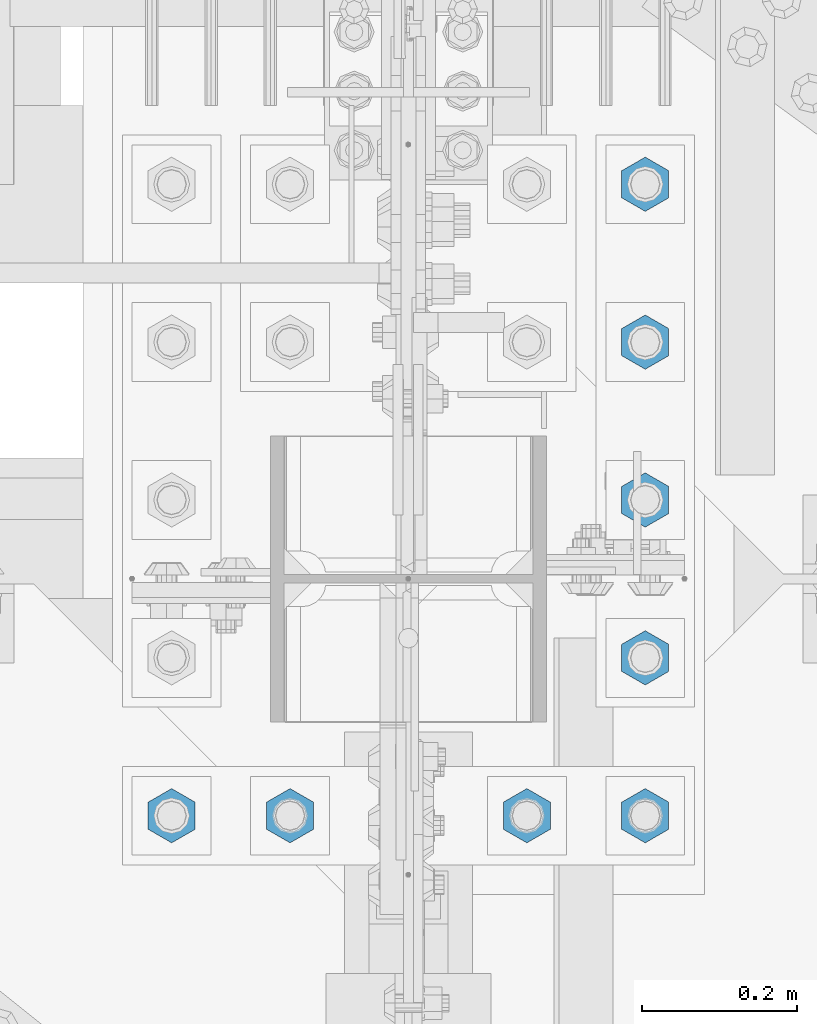
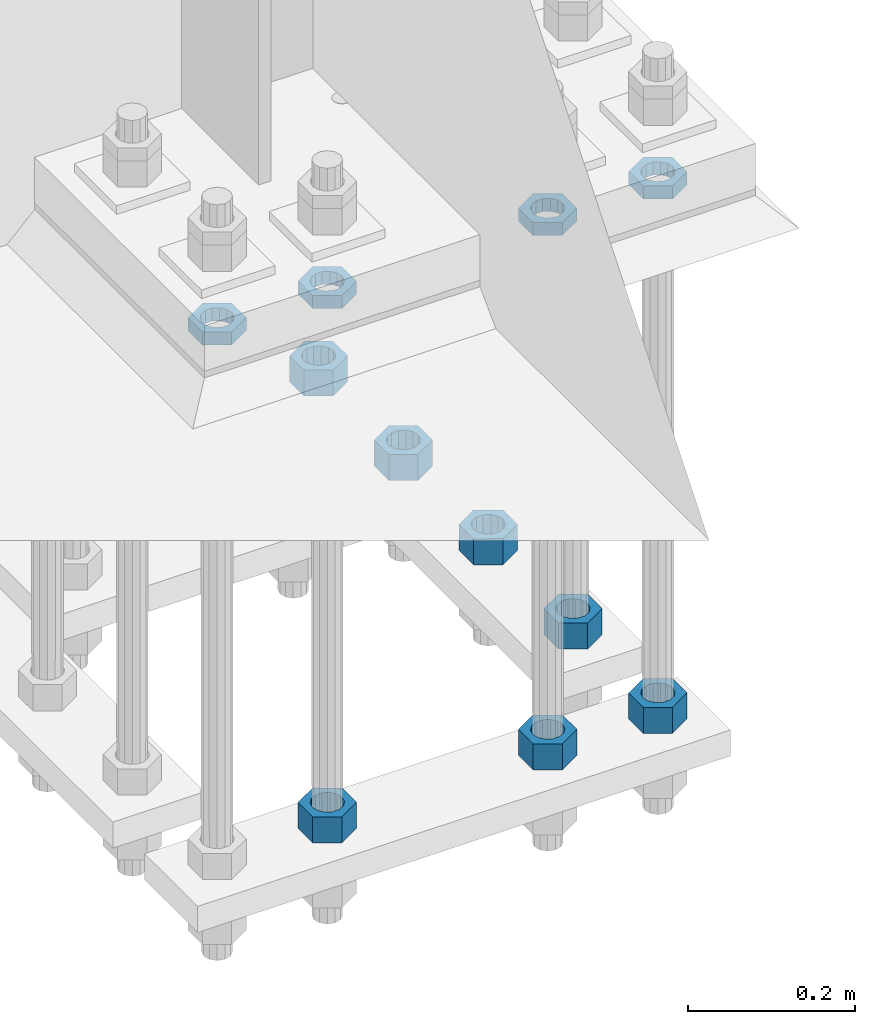
# One storey, part 2903 of 3843: 11 beams, 1 element without a shape of its own.
"""IFC2X3 building model written with IfcOpenShell, lengths in millimetres."""

from ifc_helpers import new_model, si_unit, frame, origin_with_axes, place, context, subcontext, project, spatial, faceted_brep, material, type_object, element, aggregate, save


model = new_model("IFC2X3")

# Units and contexts
model_context = context("Model", 3, precision=1e-05, world=origin_with_axes())
body_context = subcontext(model_context, "Body", "Model", "MODEL_VIEW")
ifc_project = project(units=[si_unit("LENGTHUNIT", "METRE", prefix="MILLI"), si_unit("AREAUNIT", "SQUARE_METRE"), si_unit("VOLUMEUNIT", "CUBIC_METRE"), si_unit("MASSUNIT", "GRAM", prefix="KILO"), si_unit("TIMEUNIT", "SECOND"), si_unit("PLANEANGLEUNIT", "RADIAN"), si_unit("SOLIDANGLEUNIT", "STERADIAN"), si_unit("THERMODYNAMICTEMPERATUREUNIT", "DEGREE_CELSIUS"), si_unit("LUMINOUSINTENSITYUNIT", "LUMEN")], contexts=[model_context])

# Site, building, storey
site_placement = place(None, origin_with_axes())
site = spatial("IfcSite", under=ifc_project, at=site_placement, CompositionType="ELEMENT")
building_placement = place(site_placement, origin_with_axes())
building = spatial("IfcBuilding", under=site, at=building_placement, Name="Undefined", CompositionType="ELEMENT")
storey_placement = place(building_placement, origin_with_axes())
storey = spatial("IfcBuildingStorey", under=building, at=storey_placement, Name="Undefined", CompositionType="ELEMENT", Elevation=0.0)

# Assembly, beams
assembly_placement = place(storey_placement, origin_with_axes())
assembly = element("IfcElementAssembly", 1, at=assembly_placement, inside=storey, Name="TEMPLATE", AssemblyPlace="NOTDEFINED", PredefinedType="RIGID_FRAME")
ifc_material = material(Name="STEEL/A572-50")
beam_type_1 = type_object("IfcBeamType", Name="1-1/2_HEAVY_HEX_NUT", PredefinedType="NOTDEFINED")
beam_1_placement = place(assembly_placement, frame((76860.4, 91909.9, 28841.7000015259), z_axis=(1.0, 0.0, 0.0), x_axis=(0.0, 0.0, -1.0)))
beam_1 = element("IfcBeam", 2, at=beam_1_placement, type_object=beam_type_1, material=ifc_material, Name="NUT", ObjectType="1-1/2_HEAVY_HEX_NUT", context=body_context, shape_type="Brep", body=[
    faceted_brep([(0.0, -34.9199981689453, 0.0), (0.0, -17.4599990844727, -30.25), (38.0999999999985, -17.4599990844727, -30.25), (38.0999999999985, -34.9199981689453, 0.0), (0.0, 17.4599990844727, -30.25), (38.0999999999985, 17.4599990844727, -30.25), (0.0, 34.9199981689453, 0.0), (38.0999999999985, 34.9199981689453, 0.0), (0.0, 17.4599990844727, 30.25), (38.0999999999985, 17.4599990844727, 30.25), (0.0, -17.4599990844727, 30.25), (38.0999999999985, -17.4599990844727, 30.25), (0.0, 0.0, 20.6399993896484), (0.0, 8.9553601105581, 18.5959968835959), (38.0999999999985, 8.9553601105581, 18.5959968835959), (38.0999999999985, 0.0, 20.6399993896484), (0.0, 16.1370013209525, 12.8688291298167), (38.0999999999985, 16.1370013209525, 12.8688291298167), (0.0, 20.1225115123816, 4.59283194104501), (38.0999999999985, 20.1225115123816, 4.59283194104501), (0.0, 20.1225115123816, -4.59283194104501), (38.0999999999985, 20.1225115123816, -4.59283194104501), (0.0, 16.1370013209525, -12.8688291298167), (38.0999999999985, 16.1370013209525, -12.8688291298167), (0.0, 8.9553601105581, -18.5959968835959), (38.0999999999985, 8.9553601105581, -18.5959968835959), (0.0, 0.0, -20.6399993896484), (38.0999999999985, 0.0, -20.6399993896484), (0.0, -8.9553601105581, -18.5959968835959), (38.0999999999985, -8.9553601105581, -18.5959968835959), (0.0, -16.1370013209525, -12.8688291298167), (38.0999999999985, -16.1370013209525, -12.8688291298167), (0.0, -20.1225115123816, -4.59283194104501), (38.0999999999985, -20.1225115123816, -4.59283194104501), (0.0, -20.1225115123816, 4.59283194104501), (38.0999999999985, -20.1225115123816, 4.59283194104501), (0.0, -16.1370013209525, 12.8688291298167), (38.0999999999985, -16.1370013209525, 12.8688291298167), (0.0, -8.9553601105581, 18.5959968835959), (38.0999999999985, -8.9553601105581, 18.5959968835959)], [[[0, 1, 2, 3]], [[1, 4, 5, 2]], [[4, 6, 7, 5]], [[6, 8, 9, 7]], [[8, 10, 11, 9]], [[10, 0, 3, 11]], [[12, 13, 14, 15]], [[13, 16, 17, 14]], [[16, 18, 19, 17]], [[18, 20, 21, 19]], [[20, 22, 23, 21]], [[22, 24, 25, 23]], [[24, 26, 27, 25]], [[26, 28, 29, 27]], [[28, 30, 31, 29]], [[30, 32, 33, 31]], [[32, 34, 35, 33]], [[34, 36, 37, 35]], [[36, 38, 39, 37]], [[38, 12, 15, 39]], [[5, 7, 9, 11, 3, 2], [17, 19, 21, 23, 25, 27, 29, 31, 33, 35, 37, 39, 15, 14]], [[10, 8, 6, 4, 1, 0], [38, 36, 34, 32, 30, 28, 26, 24, 22, 20, 18, 16, 13, 12]]]),
])
beam_2_placement = place(assembly_placement, frame((77165.2, 91909.9, 28841.7000015259), z_axis=(1.0, 0.0, 0.0), x_axis=(0.0, 0.0, -1.0)))
beam_2 = element("IfcBeam", 3, at=beam_2_placement, type_object=beam_type_1, material=ifc_material, Name="NUT", ObjectType="1-1/2_HEAVY_HEX_NUT", context=body_context, shape_type="Brep", body=[
    faceted_brep([(0.0, -34.9199981689453, 0.0), (0.0, -17.4599990844727, -30.25), (38.0999999999985, -17.4599990844727, -30.25), (38.0999999999985, -34.9199981689453, 0.0), (0.0, 17.4599990844727, -30.25), (38.0999999999985, 17.4599990844727, -30.25), (0.0, 34.9199981689453, 0.0), (38.0999999999985, 34.9199981689453, 0.0), (0.0, 17.4599990844727, 30.25), (38.0999999999985, 17.4599990844727, 30.25), (0.0, -17.4599990844727, 30.25), (38.0999999999985, -17.4599990844727, 30.25), (0.0, 0.0, 20.6399993896484), (0.0, 8.9553601105581, 18.5959968835959), (38.0999999999985, 8.9553601105581, 18.5959968835959), (38.0999999999985, 0.0, 20.6399993896484), (0.0, 16.1370013209525, 12.8688291298167), (38.0999999999985, 16.1370013209525, 12.8688291298167), (0.0, 20.1225115123816, 4.59283194104501), (38.0999999999985, 20.1225115123816, 4.59283194104501), (0.0, 20.1225115123816, -4.59283194104501), (38.0999999999985, 20.1225115123816, -4.59283194104501), (0.0, 16.1370013209525, -12.8688291298167), (38.0999999999985, 16.1370013209525, -12.8688291298167), (0.0, 8.9553601105581, -18.5959968835959), (38.0999999999985, 8.9553601105581, -18.5959968835959), (0.0, 0.0, -20.6399993896484), (38.0999999999985, 0.0, -20.6399993896484), (0.0, -8.9553601105581, -18.5959968835959), (38.0999999999985, -8.9553601105581, -18.5959968835959), (0.0, -16.1370013209525, -12.8688291298167), (38.0999999999985, -16.1370013209525, -12.8688291298167), (0.0, -20.1225115123816, -4.59283194104501), (38.0999999999985, -20.1225115123816, -4.59283194104501), (0.0, -20.1225115123816, 4.59283194104501), (38.0999999999985, -20.1225115123816, 4.59283194104501), (0.0, -16.1370013209525, 12.8688291298167), (38.0999999999985, -16.1370013209525, 12.8688291298167), (0.0, -8.9553601105581, 18.5959968835959), (38.0999999999985, -8.9553601105581, 18.5959968835959)], [[[0, 1, 2, 3]], [[1, 4, 5, 2]], [[4, 6, 7, 5]], [[6, 8, 9, 7]], [[8, 10, 11, 9]], [[10, 0, 3, 11]], [[12, 13, 14, 15]], [[13, 16, 17, 14]], [[16, 18, 19, 17]], [[18, 20, 21, 19]], [[20, 22, 23, 21]], [[22, 24, 25, 23]], [[24, 26, 27, 25]], [[26, 28, 29, 27]], [[28, 30, 31, 29]], [[30, 32, 33, 31]], [[32, 34, 35, 33]], [[34, 36, 37, 35]], [[36, 38, 39, 37]], [[38, 12, 15, 39]], [[5, 7, 9, 11, 3, 2], [17, 19, 21, 23, 25, 27, 29, 31, 33, 35, 37, 39, 15, 14]], [[10, 8, 6, 4, 1, 0], [38, 36, 34, 32, 30, 28, 26, 24, 22, 20, 18, 16, 13, 12]]]),
])
beam_3_placement = place(assembly_placement, frame((77317.6, 91909.9, 28841.7000015259), z_axis=(1.0, 0.0, 0.0), x_axis=(0.0, 0.0, -1.0)))
beam_3 = element("IfcBeam", 4, at=beam_3_placement, type_object=beam_type_1, material=ifc_material, Name="NUT", ObjectType="1-1/2_HEAVY_HEX_NUT", context=body_context, shape_type="Brep", body=[
    faceted_brep([(0.0, -34.9199981689453, 0.0), (0.0, -17.4599990844727, -30.25), (38.0999999999985, -17.4599990844727, -30.25), (38.0999999999985, -34.9199981689453, 0.0), (0.0, 17.4599990844727, -30.25), (38.0999999999985, 17.4599990844727, -30.25), (0.0, 34.9199981689453, 0.0), (38.0999999999985, 34.9199981689453, 0.0), (0.0, 17.4599990844727, 30.25), (38.0999999999985, 17.4599990844727, 30.25), (0.0, -17.4599990844727, 30.25), (38.0999999999985, -17.4599990844727, 30.25), (0.0, 0.0, 20.6399993896484), (0.0, 8.9553601105581, 18.5959968835959), (38.0999999999985, 8.9553601105581, 18.5959968835959), (38.0999999999985, 0.0, 20.6399993896484), (0.0, 16.1370013209525, 12.8688291298167), (38.0999999999985, 16.1370013209525, 12.8688291298167), (0.0, 20.1225115123816, 4.59283194104501), (38.0999999999985, 20.1225115123816, 4.59283194104501), (0.0, 20.1225115123816, -4.59283194104501), (38.0999999999985, 20.1225115123816, -4.59283194104501), (0.0, 16.1370013209525, -12.8688291298167), (38.0999999999985, 16.1370013209525, -12.8688291298167), (0.0, 8.9553601105581, -18.5959968835959), (38.0999999999985, 8.9553601105581, -18.5959968835959), (0.0, 0.0, -20.6399993896484), (38.0999999999985, 0.0, -20.6399993896484), (0.0, -8.9553601105581, -18.5959968835959), (38.0999999999985, -8.9553601105581, -18.5959968835959), (0.0, -16.1370013209525, -12.8688291298167), (38.0999999999985, -16.1370013209525, -12.8688291298167), (0.0, -20.1225115123816, -4.59283194104501), (38.0999999999985, -20.1225115123816, -4.59283194104501), (0.0, -20.1225115123816, 4.59283194104501), (38.0999999999985, -20.1225115123816, 4.59283194104501), (0.0, -16.1370013209525, 12.8688291298167), (38.0999999999985, -16.1370013209525, 12.8688291298167), (0.0, -8.9553601105581, 18.5959968835959), (38.0999999999985, -8.9553601105581, 18.5959968835959)], [[[0, 1, 2, 3]], [[1, 4, 5, 2]], [[4, 6, 7, 5]], [[6, 8, 9, 7]], [[8, 10, 11, 9]], [[10, 0, 3, 11]], [[12, 13, 14, 15]], [[13, 16, 17, 14]], [[16, 18, 19, 17]], [[18, 20, 21, 19]], [[20, 22, 23, 21]], [[22, 24, 25, 23]], [[24, 26, 27, 25]], [[26, 28, 29, 27]], [[28, 30, 31, 29]], [[30, 32, 33, 31]], [[32, 34, 35, 33]], [[34, 36, 37, 35]], [[36, 38, 39, 37]], [[38, 12, 15, 39]], [[5, 7, 9, 11, 3, 2], [17, 19, 21, 23, 25, 27, 29, 31, 33, 35, 37, 39, 15, 14]], [[10, 8, 6, 4, 1, 0], [38, 36, 34, 32, 30, 28, 26, 24, 22, 20, 18, 16, 13, 12]]]),
])
beam_4_placement = place(assembly_placement, frame((77317.6, 92113.1, 28841.7000015259), z_axis=(1.0, 0.0, 0.0), x_axis=(0.0, 0.0, -1.0)))
beam_4 = element("IfcBeam", 5, at=beam_4_placement, type_object=beam_type_1, material=ifc_material, Name="NUT", ObjectType="1-1/2_HEAVY_HEX_NUT", context=body_context, shape_type="Brep", body=[
    faceted_brep([(0.0, -34.9199981689453, 0.0), (0.0, -17.4599990844727, -30.25), (38.0999999999985, -17.4599990844727, -30.25), (38.0999999999985, -34.9199981689453, 0.0), (0.0, 17.4599990844727, -30.25), (38.0999999999985, 17.4599990844727, -30.25), (0.0, 34.9199981689453, 0.0), (38.0999999999985, 34.9199981689453, 0.0), (0.0, 17.4599990844727, 30.25), (38.0999999999985, 17.4599990844727, 30.25), (0.0, -17.4599990844727, 30.25), (38.0999999999985, -17.4599990844727, 30.25), (0.0, 0.0, 20.6399993896484), (0.0, 8.9553601105581, 18.5959968835959), (38.0999999999985, 8.9553601105581, 18.5959968835959), (38.0999999999985, 0.0, 20.6399993896484), (0.0, 16.1370013209525, 12.8688291298167), (38.0999999999985, 16.1370013209525, 12.8688291298167), (0.0, 20.1225115123816, 4.59283194104501), (38.0999999999985, 20.1225115123816, 4.59283194104501), (0.0, 20.1225115123816, -4.59283194104501), (38.0999999999985, 20.1225115123816, -4.59283194104501), (0.0, 16.1370013209525, -12.8688291298167), (38.0999999999985, 16.1370013209525, -12.8688291298167), (0.0, 8.9553601105581, -18.5959968835959), (38.0999999999985, 8.9553601105581, -18.5959968835959), (0.0, 0.0, -20.6399993896484), (38.0999999999985, 0.0, -20.6399993896484), (0.0, -8.9553601105581, -18.5959968835959), (38.0999999999985, -8.9553601105581, -18.5959968835959), (0.0, -16.1370013209525, -12.8688291298167), (38.0999999999985, -16.1370013209525, -12.8688291298167), (0.0, -20.1225115123816, -4.59283194104501), (38.0999999999985, -20.1225115123816, -4.59283194104501), (0.0, -20.1225115123816, 4.59283194104501), (38.0999999999985, -20.1225115123816, 4.59283194104501), (0.0, -16.1370013209525, 12.8688291298167), (38.0999999999985, -16.1370013209525, 12.8688291298167), (0.0, -8.9553601105581, 18.5959968835959), (38.0999999999985, -8.9553601105581, 18.5959968835959)], [[[0, 1, 2, 3]], [[1, 4, 5, 2]], [[4, 6, 7, 5]], [[6, 8, 9, 7]], [[8, 10, 11, 9]], [[10, 0, 3, 11]], [[12, 13, 14, 15]], [[13, 16, 17, 14]], [[16, 18, 19, 17]], [[18, 20, 21, 19]], [[20, 22, 23, 21]], [[22, 24, 25, 23]], [[24, 26, 27, 25]], [[26, 28, 29, 27]], [[28, 30, 31, 29]], [[30, 32, 33, 31]], [[32, 34, 35, 33]], [[34, 36, 37, 35]], [[36, 38, 39, 37]], [[38, 12, 15, 39]], [[5, 7, 9, 11, 3, 2], [17, 19, 21, 23, 25, 27, 29, 31, 33, 35, 37, 39, 15, 14]], [[10, 8, 6, 4, 1, 0], [38, 36, 34, 32, 30, 28, 26, 24, 22, 20, 18, 16, 13, 12]]]),
])
beam_5_placement = place(assembly_placement, frame((77317.6, 92316.3, 28841.7000015259), z_axis=(1.0, 0.0, 0.0), x_axis=(0.0, 0.0, -1.0)))
beam_5 = element("IfcBeam", 6, at=beam_5_placement, type_object=beam_type_1, material=ifc_material, Name="NUT", ObjectType="1-1/2_HEAVY_HEX_NUT", context=body_context, shape_type="Brep", body=[
    faceted_brep([(0.0, -34.9199981689453, 0.0), (0.0, -17.4599990844727, -30.25), (38.0999999999985, -17.4599990844727, -30.25), (38.0999999999985, -34.9199981689453, 0.0), (0.0, 17.4599990844727, -30.25), (38.0999999999985, 17.4599990844727, -30.25), (0.0, 34.9199981689453, 0.0), (38.0999999999985, 34.9199981689453, 0.0), (0.0, 17.4599990844727, 30.25), (38.0999999999985, 17.4599990844727, 30.25), (0.0, -17.4599990844727, 30.25), (38.0999999999985, -17.4599990844727, 30.25), (0.0, 0.0, 20.6399993896484), (0.0, 8.9553601105581, 18.5959968835959), (38.0999999999985, 8.9553601105581, 18.5959968835959), (38.0999999999985, 0.0, 20.6399993896484), (0.0, 16.1370013209525, 12.8688291298167), (38.0999999999985, 16.1370013209525, 12.8688291298167), (0.0, 20.1225115123816, 4.59283194104501), (38.0999999999985, 20.1225115123816, 4.59283194104501), (0.0, 20.1225115123816, -4.59283194104501), (38.0999999999985, 20.1225115123816, -4.59283194104501), (0.0, 16.1370013209525, -12.8688291298167), (38.0999999999985, 16.1370013209525, -12.8688291298167), (0.0, 8.9553601105581, -18.5959968835959), (38.0999999999985, 8.9553601105581, -18.5959968835959), (0.0, 0.0, -20.6399993896484), (38.0999999999985, 0.0, -20.6399993896484), (0.0, -8.9553601105581, -18.5959968835959), (38.0999999999985, -8.9553601105581, -18.5959968835959), (0.0, -16.1370013209525, -12.8688291298167), (38.0999999999985, -16.1370013209525, -12.8688291298167), (0.0, -20.1225115123816, -4.59283194104501), (38.0999999999985, -20.1225115123816, -4.59283194104501), (0.0, -20.1225115123816, 4.59283194104501), (38.0999999999985, -20.1225115123816, 4.59283194104501), (0.0, -16.1370013209525, 12.8688291298167), (38.0999999999985, -16.1370013209525, 12.8688291298167), (0.0, -8.9553601105581, 18.5959968835959), (38.0999999999985, -8.9553601105581, 18.5959968835959)], [[[0, 1, 2, 3]], [[1, 4, 5, 2]], [[4, 6, 7, 5]], [[6, 8, 9, 7]], [[8, 10, 11, 9]], [[10, 0, 3, 11]], [[12, 13, 14, 15]], [[13, 16, 17, 14]], [[16, 18, 19, 17]], [[18, 20, 21, 19]], [[20, 22, 23, 21]], [[22, 24, 25, 23]], [[24, 26, 27, 25]], [[26, 28, 29, 27]], [[28, 30, 31, 29]], [[30, 32, 33, 31]], [[32, 34, 35, 33]], [[34, 36, 37, 35]], [[36, 38, 39, 37]], [[38, 12, 15, 39]], [[5, 7, 9, 11, 3, 2], [17, 19, 21, 23, 25, 27, 29, 31, 33, 35, 37, 39, 15, 14]], [[10, 8, 6, 4, 1, 0], [38, 36, 34, 32, 30, 28, 26, 24, 22, 20, 18, 16, 13, 12]]]),
])
beam_6_placement = place(assembly_placement, frame((77317.6, 92519.5, 28841.7000015259), z_axis=(-1.0, 0.0, 0.0), x_axis=(0.0, 0.0, -1.0)))
beam_6 = element("IfcBeam", 7, at=beam_6_placement, type_object=beam_type_1, material=ifc_material, Name="NUT", ObjectType="1-1/2_HEAVY_HEX_NUT", context=body_context, shape_type="Brep", body=[
    faceted_brep([(0.0, -34.9199981689453, 0.0), (0.0, -17.4599990844727, -30.25), (38.0999999999985, -17.4599990844727, -30.25), (38.0999999999985, -34.9199981689453, 0.0), (0.0, 17.4599990844727, -30.25), (38.0999999999985, 17.4599990844727, -30.25), (0.0, 34.9199981689453, 0.0), (38.0999999999985, 34.9199981689453, 0.0), (0.0, 17.4599990844727, 30.25), (38.0999999999985, 17.4599990844727, 30.25), (0.0, -17.4599990844727, 30.25), (38.0999999999985, -17.4599990844727, 30.25), (0.0, 0.0, 20.6399993896484), (0.0, 8.9553601105581, 18.5959968835959), (38.0999999999985, 8.9553601105581, 18.5959968835959), (38.0999999999985, 0.0, 20.6399993896484), (0.0, 16.1370013209525, 12.8688291298167), (38.0999999999985, 16.1370013209525, 12.8688291298167), (0.0, 20.1225115123816, 4.59283194104501), (38.0999999999985, 20.1225115123816, 4.59283194104501), (0.0, 20.1225115123816, -4.59283194104501), (38.0999999999985, 20.1225115123816, -4.59283194104501), (0.0, 16.1370013209525, -12.8688291298167), (38.0999999999985, 16.1370013209525, -12.8688291298167), (0.0, 8.9553601105581, -18.5959968835959), (38.0999999999985, 8.9553601105581, -18.5959968835959), (0.0, 0.0, -20.6399993896484), (38.0999999999985, 0.0, -20.6399993896484), (0.0, -8.9553601105581, -18.5959968835959), (38.0999999999985, -8.9553601105581, -18.5959968835959), (0.0, -16.1370013209525, -12.8688291298167), (38.0999999999985, -16.1370013209525, -12.8688291298167), (0.0, -20.1225115123816, -4.59283194104501), (38.0999999999985, -20.1225115123816, -4.59283194104501), (0.0, -20.1225115123816, 4.59283194104501), (38.0999999999985, -20.1225115123816, 4.59283194104501), (0.0, -16.1370013209525, 12.8688291298167), (38.0999999999985, -16.1370013209525, 12.8688291298167), (0.0, -8.9553601105581, 18.5959968835959), (38.0999999999985, -8.9553601105581, 18.5959968835959)], [[[0, 1, 2, 3]], [[1, 4, 5, 2]], [[4, 6, 7, 5]], [[6, 8, 9, 7]], [[8, 10, 11, 9]], [[10, 0, 3, 11]], [[12, 13, 14, 15]], [[13, 16, 17, 14]], [[16, 18, 19, 17]], [[18, 20, 21, 19]], [[20, 22, 23, 21]], [[22, 24, 25, 23]], [[24, 26, 27, 25]], [[26, 28, 29, 27]], [[28, 30, 31, 29]], [[30, 32, 33, 31]], [[32, 34, 35, 33]], [[34, 36, 37, 35]], [[36, 38, 39, 37]], [[38, 12, 15, 39]], [[5, 7, 9, 11, 3, 2], [17, 19, 21, 23, 25, 27, 29, 31, 33, 35, 37, 39, 15, 14]], [[10, 8, 6, 4, 1, 0], [38, 36, 34, 32, 30, 28, 26, 24, 22, 20, 18, 16, 13, 12]]]),
])
beam_7_placement = place(assembly_placement, frame((77317.6, 92722.7, 28841.7000015259), z_axis=(-1.0, 0.0, 0.0), x_axis=(0.0, 0.0, -1.0)))
beam_7 = element("IfcBeam", 8, at=beam_7_placement, type_object=beam_type_1, material=ifc_material, Name="NUT", ObjectType="1-1/2_HEAVY_HEX_NUT", context=body_context, shape_type="Brep", body=[
    faceted_brep([(0.0, -34.9199981689453, 0.0), (0.0, -17.4599990844727, -30.25), (38.0999999999985, -17.4599990844727, -30.25), (38.0999999999985, -34.9199981689453, 0.0), (0.0, 17.4599990844727, -30.25), (38.0999999999985, 17.4599990844727, -30.25), (0.0, 34.9199981689453, 0.0), (38.0999999999985, 34.9199981689453, 0.0), (0.0, 17.4599990844727, 30.25), (38.0999999999985, 17.4599990844727, 30.25), (0.0, -17.4599990844727, 30.25), (38.0999999999985, -17.4599990844727, 30.25), (0.0, 0.0, 20.6399993896484), (0.0, 8.9553601105581, 18.5959968835959), (38.0999999999985, 8.9553601105581, 18.5959968835959), (38.0999999999985, 0.0, 20.6399993896484), (0.0, 16.1370013209525, 12.8688291298167), (38.0999999999985, 16.1370013209525, 12.8688291298167), (0.0, 20.1225115123816, 4.59283194104501), (38.0999999999985, 20.1225115123816, 4.59283194104501), (0.0, 20.1225115123816, -4.59283194104501), (38.0999999999985, 20.1225115123816, -4.59283194104501), (0.0, 16.1370013209525, -12.8688291298167), (38.0999999999985, 16.1370013209525, -12.8688291298167), (0.0, 8.9553601105581, -18.5959968835959), (38.0999999999985, 8.9553601105581, -18.5959968835959), (0.0, 0.0, -20.6399993896484), (38.0999999999985, 0.0, -20.6399993896484), (0.0, -8.9553601105581, -18.5959968835959), (38.0999999999985, -8.9553601105581, -18.5959968835959), (0.0, -16.1370013209525, -12.8688291298167), (38.0999999999985, -16.1370013209525, -12.8688291298167), (0.0, -20.1225115123816, -4.59283194104501), (38.0999999999985, -20.1225115123816, -4.59283194104501), (0.0, -20.1225115123816, 4.59283194104501), (38.0999999999985, -20.1225115123816, 4.59283194104501), (0.0, -16.1370013209525, 12.8688291298167), (38.0999999999985, -16.1370013209525, 12.8688291298167), (0.0, -8.9553601105581, 18.5959968835959), (38.0999999999985, -8.9553601105581, 18.5959968835959)], [[[0, 1, 2, 3]], [[1, 4, 5, 2]], [[4, 6, 7, 5]], [[6, 8, 9, 7]], [[8, 10, 11, 9]], [[10, 0, 3, 11]], [[12, 13, 14, 15]], [[13, 16, 17, 14]], [[16, 18, 19, 17]], [[18, 20, 21, 19]], [[20, 22, 23, 21]], [[22, 24, 25, 23]], [[24, 26, 27, 25]], [[26, 28, 29, 27]], [[28, 30, 31, 29]], [[30, 32, 33, 31]], [[32, 34, 35, 33]], [[34, 36, 37, 35]], [[36, 38, 39, 37]], [[38, 12, 15, 39]], [[5, 7, 9, 11, 3, 2], [17, 19, 21, 23, 25, 27, 29, 31, 33, 35, 37, 39, 15, 14]], [[10, 8, 6, 4, 1, 0], [38, 36, 34, 32, 30, 28, 26, 24, 22, 20, 18, 16, 13, 12]]]),
])
beam_type_2 = type_object("IfcBeamType", Name="1-1/2_HALF_NUT", PredefinedType="NOTDEFINED")
beam_8_placement = place(assembly_placement, frame((76707.9999755859, 91909.9, 29603.7), z_axis=(1.0, 0.0, 0.0), x_axis=(0.0, 0.0, -1.0)))
beam_8 = element("IfcBeam", 9, at=beam_8_placement, type_object=beam_type_2, material=ifc_material, Name="NUT", ObjectType="1-1/2_HALF_NUT", context=body_context, shape_type="Brep", body=[
    faceted_brep([(0.0, -34.9199981689453, 0.0), (0.0, -17.4599990844727, -30.25), (19.0500000000029, -17.4599990844727, -30.25), (19.0500000000029, -34.9199981689453, 0.0), (0.0, 17.4599990844727, -30.25), (19.0500000000029, 17.4599990844727, -30.25), (0.0, 34.9199981689453, 0.0), (19.0500000000029, 34.9199981689453, 0.0), (0.0, 17.4599990844727, 30.25), (19.0500000000029, 17.4599990844727, 30.25), (0.0, -17.4599990844727, 30.25), (19.0500000000029, -17.4599990844727, 30.25), (0.0, 0.0, 20.6399993896484), (0.0, 8.9553601105581, 18.5959968835959), (19.0500000000029, 8.95536011056538, 18.5959968835959), (19.0500000000029, 0.0, 20.6399993896484), (0.0, 16.1370013209525, 12.8688291298167), (19.0500000000029, 16.1370013209489, 12.8688291298167), (0.0, 20.1225115123816, 4.59283194104501), (19.0500000000029, 20.1225115123852, 4.59283194104501), (0.0, 20.1225115123816, -4.59283194104501), (19.0500000000029, 20.1225115123852, -4.59283194104501), (0.0, 16.1370013209525, -12.8688291298167), (19.0500000000029, 16.1370013209489, -12.8688291298167), (0.0, 8.9553601105581, -18.5959968835959), (19.0500000000029, 8.95536011056538, -18.5959968835959), (0.0, 0.0, -20.6399993896484), (19.0500000000029, 0.0, -20.6399993896484), (0.0, -8.9553601105581, -18.5959968835959), (19.0500000000029, -8.95536011056538, -18.5959968835959), (0.0, -16.1370013209525, -12.8688291298167), (19.0500000000029, -16.1370013209489, -12.8688291298167), (0.0, -20.1225115123816, -4.59283194104501), (19.0500000000029, -20.1225115123852, -4.59283194104501), (0.0, -20.1225115123816, 4.59283194104501), (19.0500000000029, -20.1225115123852, 4.59283194104501), (0.0, -16.1370013209525, 12.8688291298167), (19.0500000000029, -16.1370013209489, 12.8688291298167), (0.0, -8.9553601105581, 18.5959968835959), (19.0500000000029, -8.95536011056538, 18.5959968835959)], [[[0, 1, 2, 3]], [[1, 4, 5, 2]], [[4, 6, 7, 5]], [[6, 8, 9, 7]], [[8, 10, 11, 9]], [[10, 0, 3, 11]], [[12, 13, 14, 15]], [[13, 16, 17, 14]], [[16, 18, 19, 17]], [[18, 20, 21, 19]], [[20, 22, 23, 21]], [[22, 24, 25, 23]], [[24, 26, 27, 25]], [[26, 28, 29, 27]], [[28, 30, 31, 29]], [[30, 32, 33, 31]], [[32, 34, 35, 33]], [[34, 36, 37, 35]], [[36, 38, 39, 37]], [[38, 12, 15, 39]], [[5, 7, 9, 11, 3, 2], [17, 19, 21, 23, 25, 27, 29, 31, 33, 35, 37, 39, 15, 14]], [[10, 8, 6, 4, 1, 0], [38, 36, 34, 32, 30, 28, 26, 24, 22, 20, 18, 16, 13, 12]]]),
])
beam_9_placement = place(assembly_placement, frame((76860.3999755859, 91909.9, 29603.7), z_axis=(1.0, 0.0, 0.0), x_axis=(0.0, 0.0, -1.0)))
beam_9 = element("IfcBeam", 10, at=beam_9_placement, type_object=beam_type_2, material=ifc_material, Name="NUT", ObjectType="1-1/2_HALF_NUT", context=body_context, shape_type="Brep", body=[
    faceted_brep([(0.0, -34.9199981689453, 0.0), (0.0, -17.4599990844727, -30.25), (19.0500000000029, -17.4599990844727, -30.25), (19.0500000000029, -34.9199981689453, 0.0), (0.0, 17.4599990844727, -30.25), (19.0500000000029, 17.4599990844727, -30.25), (0.0, 34.9199981689453, 0.0), (19.0500000000029, 34.9199981689453, 0.0), (0.0, 17.4599990844727, 30.25), (19.0500000000029, 17.4599990844727, 30.25), (0.0, -17.4599990844727, 30.25), (19.0500000000029, -17.4599990844727, 30.25), (0.0, 0.0, 20.6399993896484), (0.0, 8.9553601105581, 18.5959968835959), (19.0500000000029, 8.95536011056538, 18.5959968835959), (19.0500000000029, 0.0, 20.6399993896484), (0.0, 16.1370013209525, 12.8688291298167), (19.0500000000029, 16.1370013209489, 12.8688291298167), (0.0, 20.1225115123816, 4.59283194104501), (19.0500000000029, 20.1225115123852, 4.59283194104501), (0.0, 20.1225115123816, -4.59283194104501), (19.0500000000029, 20.1225115123852, -4.59283194104501), (0.0, 16.1370013209525, -12.8688291298167), (19.0500000000029, 16.1370013209489, -12.8688291298167), (0.0, 8.9553601105581, -18.5959968835959), (19.0500000000029, 8.95536011056538, -18.5959968835959), (0.0, 0.0, -20.6399993896484), (19.0500000000029, 0.0, -20.6399993896484), (0.0, -8.9553601105581, -18.5959968835959), (19.0500000000029, -8.95536011056538, -18.5959968835959), (0.0, -16.1370013209525, -12.8688291298167), (19.0500000000029, -16.1370013209489, -12.8688291298167), (0.0, -20.1225115123816, -4.59283194104501), (19.0500000000029, -20.1225115123852, -4.59283194104501), (0.0, -20.1225115123816, 4.59283194104501), (19.0500000000029, -20.1225115123852, 4.59283194104501), (0.0, -16.1370013209525, 12.8688291298167), (19.0500000000029, -16.1370013209489, 12.8688291298167), (0.0, -8.9553601105581, 18.5959968835959), (19.0500000000029, -8.95536011056538, 18.5959968835959)], [[[0, 1, 2, 3]], [[1, 4, 5, 2]], [[4, 6, 7, 5]], [[6, 8, 9, 7]], [[8, 10, 11, 9]], [[10, 0, 3, 11]], [[12, 13, 14, 15]], [[13, 16, 17, 14]], [[16, 18, 19, 17]], [[18, 20, 21, 19]], [[20, 22, 23, 21]], [[22, 24, 25, 23]], [[24, 26, 27, 25]], [[26, 28, 29, 27]], [[28, 30, 31, 29]], [[30, 32, 33, 31]], [[32, 34, 35, 33]], [[34, 36, 37, 35]], [[36, 38, 39, 37]], [[38, 12, 15, 39]], [[5, 7, 9, 11, 3, 2], [17, 19, 21, 23, 25, 27, 29, 31, 33, 35, 37, 39, 15, 14]], [[10, 8, 6, 4, 1, 0], [38, 36, 34, 32, 30, 28, 26, 24, 22, 20, 18, 16, 13, 12]]]),
])
beam_10_placement = place(assembly_placement, frame((77165.1999755859, 91909.9, 29603.7), z_axis=(1.0, 0.0, 0.0), x_axis=(0.0, 0.0, -1.0)))
beam_10 = element("IfcBeam", 11, at=beam_10_placement, type_object=beam_type_2, material=ifc_material, Name="NUT", ObjectType="1-1/2_HALF_NUT", context=body_context, shape_type="Brep", body=[
    faceted_brep([(0.0, -34.9199981689453, 0.0), (0.0, -17.4599990844727, -30.25), (19.0500000000029, -17.4599990844727, -30.25), (19.0500000000029, -34.9199981689453, 0.0), (0.0, 17.4599990844727, -30.25), (19.0500000000029, 17.4599990844727, -30.25), (0.0, 34.9199981689453, 0.0), (19.0500000000029, 34.9199981689453, 0.0), (0.0, 17.4599990844727, 30.25), (19.0500000000029, 17.4599990844727, 30.25), (0.0, -17.4599990844727, 30.25), (19.0500000000029, -17.4599990844727, 30.25), (0.0, 0.0, 20.6399993896484), (0.0, 8.9553601105581, 18.5959968835959), (19.0500000000029, 8.95536011056538, 18.5959968835959), (19.0500000000029, 0.0, 20.6399993896484), (0.0, 16.1370013209525, 12.8688291298167), (19.0500000000029, 16.1370013209489, 12.8688291298167), (0.0, 20.1225115123816, 4.59283194104501), (19.0500000000029, 20.1225115123852, 4.59283194104501), (0.0, 20.1225115123816, -4.59283194104501), (19.0500000000029, 20.1225115123852, -4.59283194104501), (0.0, 16.1370013209525, -12.8688291298167), (19.0500000000029, 16.1370013209489, -12.8688291298167), (0.0, 8.9553601105581, -18.5959968835959), (19.0500000000029, 8.95536011056538, -18.5959968835959), (0.0, 0.0, -20.6399993896484), (19.0500000000029, 0.0, -20.6399993896484), (0.0, -8.9553601105581, -18.5959968835959), (19.0500000000029, -8.95536011056538, -18.5959968835959), (0.0, -16.1370013209525, -12.8688291298167), (19.0500000000029, -16.1370013209489, -12.8688291298167), (0.0, -20.1225115123816, -4.59283194104501), (19.0500000000029, -20.1225115123852, -4.59283194104501), (0.0, -20.1225115123816, 4.59283194104501), (19.0500000000029, -20.1225115123852, 4.59283194104501), (0.0, -16.1370013209525, 12.8688291298167), (19.0500000000029, -16.1370013209489, 12.8688291298167), (0.0, -8.9553601105581, 18.5959968835959), (19.0500000000029, -8.95536011056538, 18.5959968835959)], [[[0, 1, 2, 3]], [[1, 4, 5, 2]], [[4, 6, 7, 5]], [[6, 8, 9, 7]], [[8, 10, 11, 9]], [[10, 0, 3, 11]], [[12, 13, 14, 15]], [[13, 16, 17, 14]], [[16, 18, 19, 17]], [[18, 20, 21, 19]], [[20, 22, 23, 21]], [[22, 24, 25, 23]], [[24, 26, 27, 25]], [[26, 28, 29, 27]], [[28, 30, 31, 29]], [[30, 32, 33, 31]], [[32, 34, 35, 33]], [[34, 36, 37, 35]], [[36, 38, 39, 37]], [[38, 12, 15, 39]], [[5, 7, 9, 11, 3, 2], [17, 19, 21, 23, 25, 27, 29, 31, 33, 35, 37, 39, 15, 14]], [[10, 8, 6, 4, 1, 0], [38, 36, 34, 32, 30, 28, 26, 24, 22, 20, 18, 16, 13, 12]]]),
])
beam_11_placement = place(assembly_placement, frame((77317.5999755859, 91909.9, 29603.7), z_axis=(1.0, 0.0, 0.0), x_axis=(0.0, 0.0, -1.0)))
beam_11 = element("IfcBeam", 12, at=beam_11_placement, type_object=beam_type_2, material=ifc_material, Name="NUT", ObjectType="1-1/2_HALF_NUT", context=body_context, shape_type="Brep", body=[
    faceted_brep([(0.0, -34.9199981689453, 0.0), (0.0, -17.4599990844727, -30.25), (19.0500000000029, -17.4599990844727, -30.25), (19.0500000000029, -34.9199981689453, 0.0), (0.0, 17.4599990844727, -30.25), (19.0500000000029, 17.4599990844727, -30.25), (0.0, 34.9199981689453, 0.0), (19.0500000000029, 34.9199981689453, 0.0), (0.0, 17.4599990844727, 30.25), (19.0500000000029, 17.4599990844727, 30.25), (0.0, -17.4599990844727, 30.25), (19.0500000000029, -17.4599990844727, 30.25), (0.0, 0.0, 20.6399993896484), (0.0, 8.9553601105581, 18.5959968835959), (19.0500000000029, 8.95536011056538, 18.5959968835959), (19.0500000000029, 0.0, 20.6399993896484), (0.0, 16.1370013209525, 12.8688291298167), (19.0500000000029, 16.1370013209489, 12.8688291298167), (0.0, 20.1225115123816, 4.59283194104501), (19.0500000000029, 20.1225115123852, 4.59283194104501), (0.0, 20.1225115123816, -4.59283194104501), (19.0500000000029, 20.1225115123852, -4.59283194104501), (0.0, 16.1370013209525, -12.8688291298167), (19.0500000000029, 16.1370013209489, -12.8688291298167), (0.0, 8.9553601105581, -18.5959968835959), (19.0500000000029, 8.95536011056538, -18.5959968835959), (0.0, 0.0, -20.6399993896484), (19.0500000000029, 0.0, -20.6399993896484), (0.0, -8.9553601105581, -18.5959968835959), (19.0500000000029, -8.95536011056538, -18.5959968835959), (0.0, -16.1370013209525, -12.8688291298167), (19.0500000000029, -16.1370013209489, -12.8688291298167), (0.0, -20.1225115123816, -4.59283194104501), (19.0500000000029, -20.1225115123852, -4.59283194104501), (0.0, -20.1225115123816, 4.59283194104501), (19.0500000000029, -20.1225115123852, 4.59283194104501), (0.0, -16.1370013209525, 12.8688291298167), (19.0500000000029, -16.1370013209489, 12.8688291298167), (0.0, -8.9553601105581, 18.5959968835959), (19.0500000000029, -8.95536011056538, 18.5959968835959)], [[[0, 1, 2, 3]], [[1, 4, 5, 2]], [[4, 6, 7, 5]], [[6, 8, 9, 7]], [[8, 10, 11, 9]], [[10, 0, 3, 11]], [[12, 13, 14, 15]], [[13, 16, 17, 14]], [[16, 18, 19, 17]], [[18, 20, 21, 19]], [[20, 22, 23, 21]], [[22, 24, 25, 23]], [[24, 26, 27, 25]], [[26, 28, 29, 27]], [[28, 30, 31, 29]], [[30, 32, 33, 31]], [[32, 34, 35, 33]], [[34, 36, 37, 35]], [[36, 38, 39, 37]], [[38, 12, 15, 39]], [[5, 7, 9, 11, 3, 2], [17, 19, 21, 23, 25, 27, 29, 31, 33, 35, 37, 39, 15, 14]], [[10, 8, 6, 4, 1, 0], [38, 36, 34, 32, 30, 28, 26, 24, 22, 20, 18, 16, 13, 12]]]),
])
aggregate(assembly, [beam_1, beam_2, beam_3, beam_4, beam_5, beam_6, beam_7, beam_8, beam_9, beam_10, beam_11])

save(model, "model.ifc")
